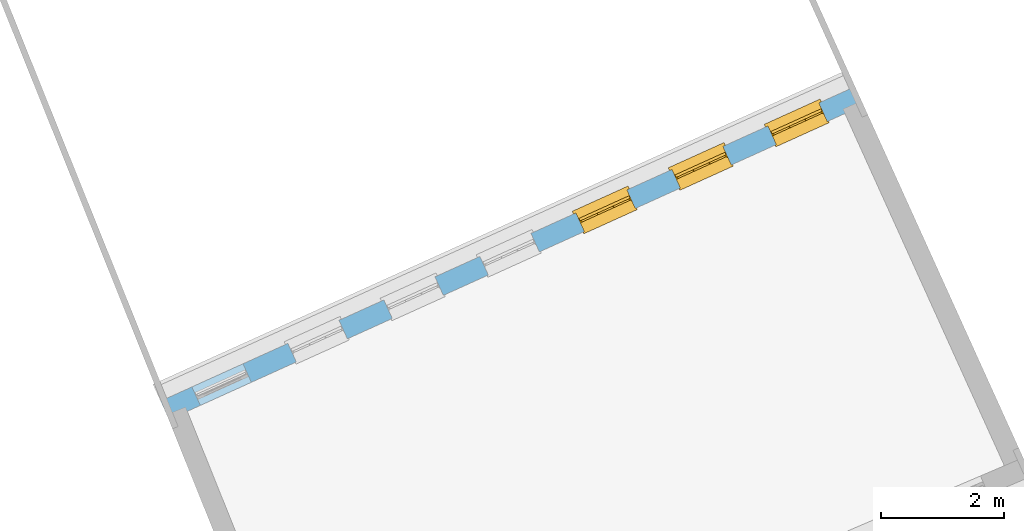
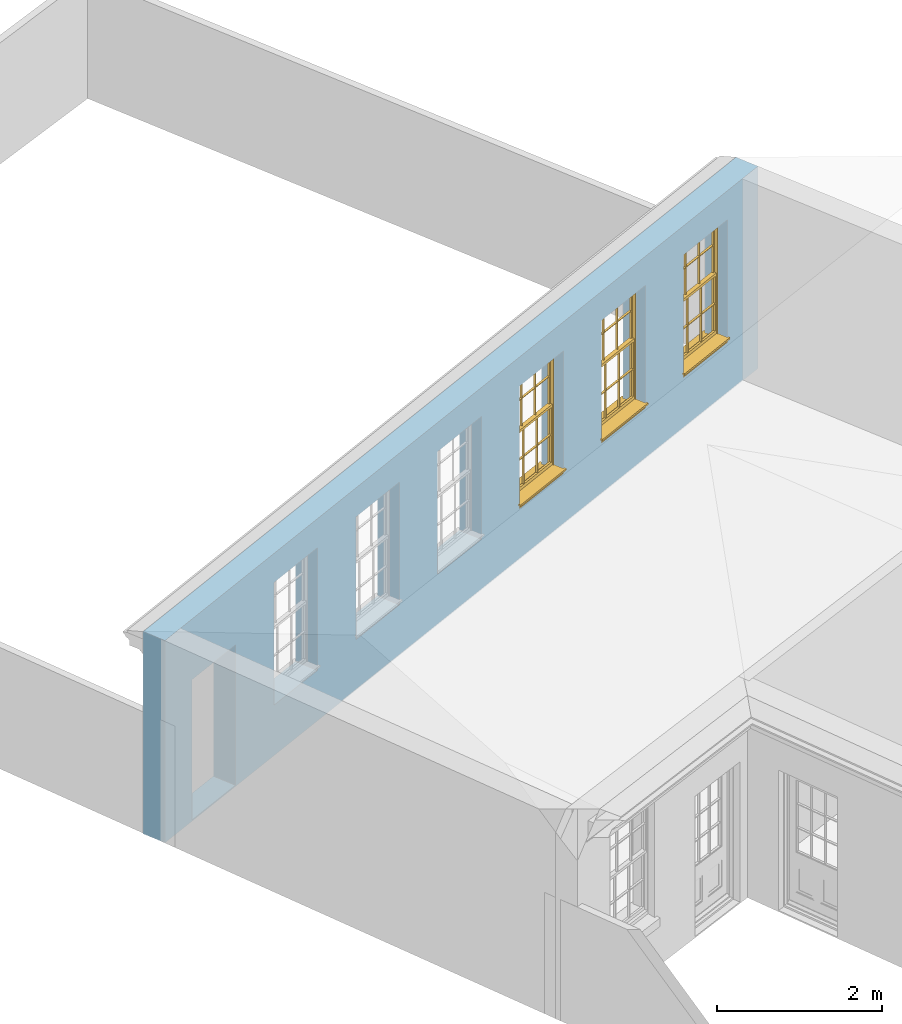
# One storey, part 15 of 19: 3 windows, 7 openings, plus 1 element that does not belong to this part.
"""IFC2X3 building model written with IfcOpenShell, lengths in metres."""

from ifc_helpers import new_model, si_unit, frame, origin, place, context, subcontext, project, spatial, polyline, outline, extrude, faceted_brep, material, layer, layer_set, layer_usage, element, fill, save


model = new_model("IFC2X3")

# Units and contexts
model_context = context("Model", 3, world=origin())
body_context = subcontext(model_context, "Body", "Model", "MODEL_VIEW")
ifc_project = project(units=[si_unit("PLANEANGLEUNIT", "RADIAN"), si_unit("MASSUNIT", "GRAM", prefix="KILO"), si_unit("FORCEUNIT", "NEWTON", prefix="KILO"), si_unit("LENGTHUNIT", "METRE")], contexts=[model_context])

# Site, building, storey
site_placement = place(None, origin())
site = spatial("IfcSite", under=ifc_project, at=site_placement, CompositionType="ELEMENT")
building_placement = place(None, origin())
building = spatial("IfcBuilding", under=site, at=building_placement, Name="Building plot-0", CompositionType="ELEMENT")
storey_placement = place(None, origin())
storey = spatial("IfcBuildingStorey", under=building, at=storey_placement, Name="Floor 0", CompositionType="ELEMENT", Elevation=0.0)

# Wall, openings, windows
ifc_material = material(Name="Masonry")
ifc_layer = layer(ifc_material, 0.33, ventilated=False)
ifc_layer_set = layer_set([ifc_layer], Name="My Wall")
ifc_layer_usage = layer_usage(ifc_layer_set, "AXIS2", "NEGATIVE", 0.08)
wall_placement = place(storey_placement, origin())
wall = element("IfcWallStandardCase", 1, at=wall_placement, inside=storey, material=ifc_layer_usage, Name="exterior", context=body_context, shape_type="SweptSolid", body=[
    extrude(outline(polyline([(21.5007118437475, 40.3889268355029), (21.3645733407012, 40.6895367288669), (10.0949852202286, 35.5858295970064), (10.2311237232749, 35.2852197036424), (21.5007118437475, 40.3889268355029)])), origin(), (0.0, 0.0, 1.0), 3.0),
])
opening_1_placement = place(storey_placement, frame((0.0, 0.0, 0.75)))
opening_1 = element("IfcOpeningElement", 2, at=opening_1_placement, cuts=wall, Name="Opening", ObjectType="Opening", context=body_context, shape_type="SweptSolid", body=[
    extrude(outline(polyline([(20.7788788084242, 40.4242907119302), (19.9499242539963, 40.048878476257), (20.0860627570426, 39.748268582893), (20.9150173114706, 40.1236808185662), (20.7788788084242, 40.4242907119302)])), origin(), (0.0, 0.0, 1.0), 1.82),
])
opening_2_placement = place(storey_placement, frame((0.0, 0.0, 0.75)))
opening_2 = element("IfcOpeningElement", 3, at=opening_2_placement, cuts=wall, Name="Opening", ObjectType="Opening", context=body_context, shape_type="SweptSolid", body=[
    extrude(outline(polyline([(19.2211729973563, 39.7188457415993), (18.3922184429283, 39.3434335059261), (18.5283569459746, 39.0428236125621), (19.3573115004026, 39.4182358482353), (19.2211729973563, 39.7188457415993)])), origin(), (0.0, 0.0, 1.0), 1.82),
])
opening_3_placement = place(storey_placement, frame((0.0, 0.0, 0.75)))
opening_3 = element("IfcOpeningElement", 4, at=opening_3_placement, cuts=wall, Name="Opening", ObjectType="Opening", context=body_context, shape_type="SweptSolid", body=[
    extrude(outline(polyline([(17.6634671862884, 39.0134007712684), (16.8345126318604, 38.6379885355952), (16.9706511349067, 38.3373786422312), (17.7996056893347, 38.7127908779044), (17.6634671862884, 39.0134007712684)])), origin(), (0.0, 0.0, 1.0), 1.82),
])
opening_4_placement = place(storey_placement, frame((0.0, 0.0, 0.75)))
element("IfcOpeningElement", 5, at=opening_4_placement, cuts=wall, Name="Opening", ObjectType="Opening", context=body_context, shape_type="SweptSolid", body=[
    extrude(outline(polyline([(16.1057613752204, 38.3079558009375), (15.2768068207924, 37.9325435652643), (15.4129453238388, 37.6319336719003), (16.2418998782667, 38.0073459075735), (16.1057613752204, 38.3079558009375)])), origin(), (0.0, 0.0, 1.0), 1.82),
])
opening_5_placement = place(storey_placement, frame((0.0, 0.0, 0.75)))
element("IfcOpeningElement", 6, at=opening_5_placement, cuts=wall, Name="Opening", ObjectType="Opening", context=body_context, shape_type="SweptSolid", body=[
    extrude(outline(polyline([(14.5480555641525, 37.6025108306066), (13.7191010097245, 37.2270985949334), (13.8552395127708, 36.9264887015694), (14.6841940671988, 37.3019009372426), (14.5480555641525, 37.6025108306066)])), origin(), (0.0, 0.0, 1.0), 1.82),
])
opening_6_placement = place(storey_placement, frame((0.0, 0.0, 0.75)))
element("IfcOpeningElement", 7, at=opening_6_placement, cuts=wall, Name="Opening", ObjectType="Opening", context=body_context, shape_type="SweptSolid", body=[
    extrude(outline(polyline([(12.9903497530845, 36.8970658602757), (12.1613951986565, 36.5216536246025), (12.2975337017029, 36.2210437312385), (13.1264882561308, 36.5964559669117), (12.9903497530845, 36.8970658602757)])), origin(), (0.0, 0.0, 1.0), 1.82),
])
opening_7_placement = place(storey_placement, frame((0.0, 0.0, 0.02)))
element("IfcOpeningElement", 8, at=opening_7_placement, cuts=wall, Name="Opening", ObjectType="Opening", context=body_context, shape_type="SweptSolid", body=[
    extrude(outline(polyline([(11.4326439420166, 36.1916208899448), (10.6036893875886, 35.8162086542716), (10.7398278906349, 35.5155987609077), (11.5687824450629, 35.8910109965808), (11.4326439420166, 36.1916208899448)])), origin(), (0.0, 0.0, 1.0), 2.08),
])
window_1_placement = place(storey_placement, frame((20.8820140380048, 40.1965559442302, 0.75), z_axis=(0.0, 0.0, 1.0), x_axis=(-0.82895455442797, -0.37541223567316, 0.0)))
window_1 = element("IfcWindow", 9, at=window_1_placement, inside=storey, Name="bedroom window", OverallHeight=1.82, OverallWidth=0.91, context=body_context, shape_type="Brep", held_by="IfcProductRepresentation", body=[
    faceted_brep([(0.033125, -0.105, 0.975209), (0.01, -0.105, 0.975209), (0.033125, -0.105, 1.376042), (0.876875, -0.105, 0.975209), (0.876875, -0.105, 1.376042), (0.9, -0.105, 0.975209), (0.876875, -0.105, 1.386042), (0.876875, -0.105, 1.786875), (0.9, -0.105, 1.81), (0.033125, -0.105, 1.786875), (0.033125, -0.105, 1.386042), (0.01, -0.105, 1.81), (0.876875, -0.135, 1.376042), (0.876875, -0.135, 0.975209), (0.9, -0.135, 0.937083), (0.033125, -0.135, 1.786875), (0.01, -0.135, 1.81), (0.033125, -0.135, 1.386042), (0.01, -0.135, 0.937083), (0.033125, -0.135, 0.975209), (0.033125, -0.135, 1.376042), (0.876875, -0.135, 1.786875), (0.876875, -0.135, 1.386042), (0.9, -0.135, 1.81), (0.033125, -0.105, 0.937083), (0.01, -0.105, 0.937083), (0.033125, -0.105, 0.53625), (0.876875, -0.105, 0.937083), (0.876875, -0.105, 0.53625), (0.9, -0.105, 0.937083), (0.876875, -0.105, 0.52625), (0.876875, -0.105, 0.125417), (0.9, -0.105, 0.077167), (0.033125, -0.105, 0.125417), (0.033125, -0.105, 0.52625), (0.01, -0.105, 0.077167), (-0.0425, -0.25, 0.01), (-0.0425, -0.3, 0.001667), (0.0, -0.25, 0.01), (0.9525, -0.25, 0.01), (0.91, -0.25, 0.01), (0.9525, -0.3, 0.001667), (-0.02, 0.08, 0.077167), (0.0, 0.08, 0.077167), (-0.02, 0.11, 0.077167), (0.0, -0.06, 0.077167), (0.01, -0.06, 0.077167), (0.91, -0.06, 0.077167), (0.91, 0.08, 0.077167), (0.9, -0.06, 0.077167), (0.93, 0.08, 0.077167), (0.93, 0.11, 0.077167), (0.01, -0.075, 0.975209), (0.9, -0.075, 0.975209), (0.876875, -0.075, 0.125417), (0.876875, -0.075, 0.52625), (0.9, -0.075, 0.077167), (0.876875, -0.075, 0.53625), (0.876875, -0.075, 0.937083), (0.033125, -0.075, 0.125417), (0.01, -0.075, 0.077167), (0.033125, -0.075, 0.52625), (0.033125, -0.075, 0.937083), (0.033125, -0.075, 0.53625), (-0.02, 0.08, 0.052167), (-0.02, 0.11, 0.052167), (0.93, 0.11, 0.052167), (0.93, 0.08, 0.052167), (0.91, 0.08, 0.052167), (0.0, 0.08, 0.052167), (0.91, -0.15, 0.026667), (0.0, -0.15, 0.026667), (-0.0425, -0.3, -0.123333), (0.9525, -0.3, -0.123333), (-0.0425, -0.25, -0.123333), (0.9525, -0.25, -0.123333), (0.01, -0.06, 1.81), (0.9, -0.06, 1.81), (0.0, -0.06, 1.82), (0.91, -0.06, 1.82), (0.01, -0.15, 0.077167), (0.9, -0.15, 0.077167), (0.592292, -0.105, 0.125417), (0.592292, -0.075, 0.125417), (0.317708, -0.075, 0.125417), (0.317708, -0.105, 0.125417), (0.592292, -0.105, 0.53625), (0.317708, -0.105, 0.53625), (0.317708, -0.105, 0.52625), (0.592292, -0.105, 0.52625), (0.592292, -0.075, 0.53625), (0.317708, -0.075, 0.53625), (0.592292, -0.135, 1.386042), (0.592292, -0.105, 1.386042), (0.317708, -0.105, 1.386042), (0.317708, -0.135, 1.386042), (0.317708, -0.135, 1.376042), (0.592292, -0.135, 1.376042), (0.317708, -0.105, 1.376042), (0.592292, -0.105, 1.376042), (0.602292, -0.135, 1.376042), (0.592292, -0.135, 0.975209), (0.602292, -0.135, 0.975209), (0.602292, -0.105, 0.975209), (0.592292, -0.105, 0.975209), (0.602292, -0.105, 1.376042), (0.602292, -0.075, 0.53625), (0.602292, -0.105, 0.53625), (0.317708, -0.075, 0.52625), (0.307708, -0.075, 0.125417), (0.307708, -0.075, 0.52625), (0.602292, -0.075, 0.52625), (0.602292, -0.075, 0.125417), (0.592292, -0.075, 0.52625), (0.307708, -0.075, 0.53625), (0.317708, -0.075, 0.937083), (0.307708, -0.075, 0.937083), (0.602292, -0.075, 0.937083), (0.592292, -0.075, 0.937083), (0.307708, -0.105, 0.52625), (0.307708, -0.105, 0.125417), (0.307708, -0.105, 0.53625), (0.307708, -0.105, 0.937083), (0.592292, -0.105, 0.937083), (0.317708, -0.105, 0.937083), (0.602292, -0.105, 0.937083), (0.602292, -0.105, 0.52625), (0.602292, -0.105, 0.125417), (0.307708, -0.135, 1.386042), (0.307708, -0.135, 1.376042), (0.307708, -0.135, 0.975209), (0.317708, -0.135, 0.975209), (0.317708, -0.135, 1.786875), (0.307708, -0.135, 1.786875), (0.602292, -0.135, 1.786875), (0.592292, -0.135, 1.786875), (0.602292, -0.135, 1.386042), (0.602292, -0.105, 1.386042), (0.307708, -0.105, 1.386042), (0.307708, -0.105, 1.786875), (0.317708, -0.105, 1.786875), (0.592292, -0.105, 1.786875), (0.602292, -0.105, 1.786875), (0.307708, -0.105, 1.376042), (0.317708, -0.105, 0.975209), (0.307708, -0.105, 0.975209), (0.91, -0.15, 1.82), (0.9, -0.15, 1.81), (0.01, -0.15, 1.81), (0.0, -0.15, 1.82), (0.91, -0.25, 0.0), (0.0, -0.25, 0.0), (0.91, 0.08, 0.0), (0.0, 0.08, 0.0)], [[[0, 1, 2]], [[3, 4, 5]], [[6, 7, 8]], [[9, 10, 11]], [[12, 13, 14]], [[15, 16, 17]], [[18, 19, 20]], [[21, 22, 23]], [[24, 25, 26]], [[27, 28, 29]], [[30, 31, 32]], [[33, 34, 35]], [[14, 27, 29]], [[25, 24, 18]], [[36, 37, 38]], [[39, 40, 41]], [[42, 43, 44]], [[45, 46, 43]], [[47, 48, 49]], [[50, 51, 48]], [[1, 0, 52]], [[5, 53, 3]], [[54, 55, 56]], [[57, 58, 53]], [[59, 60, 61]], [[62, 63, 52]], [[48, 43, 46, 49]], [[51, 44, 43, 48]], [[64, 42, 44, 65]], [[65, 44, 51, 66]], [[66, 51, 50, 67]], [[65, 66, 68, 69]], [[60, 56, 49, 46]], [[70, 71, 38, 40]], [[37, 41, 40, 38]], [[37, 72, 73, 41]], [[74, 75, 73, 72]], [[8, 11, 76, 77]], [[76, 78, 79, 77]], [[32, 35, 80, 81]], [[81, 80, 71, 70]], [[82, 83, 84, 85]], [[86, 87, 88, 89]], [[86, 90, 91, 87]], [[92, 93, 94, 95]], [[92, 95, 96, 97]], [[96, 98, 99, 97]], [[100, 97, 101, 102]], [[103, 104, 99, 105]], [[97, 99, 104, 101]], [[102, 103, 105, 100]], [[28, 57, 106, 107]], [[108, 84, 109, 110]], [[111, 112, 83, 113]], [[114, 110, 61, 63]], [[90, 113, 108, 91]], [[115, 91, 114, 116]], [[117, 106, 90, 118]], [[111, 106, 57, 55]], [[119, 110, 109, 120]], [[34, 61, 110, 119]], [[89, 113, 83, 82]], [[88, 108, 113, 89]], [[85, 84, 108, 88]], [[121, 114, 63, 26]], [[122, 116, 114, 121]], [[123, 118, 90, 86]], [[87, 91, 115, 124]], [[107, 106, 117, 125]], [[126, 111, 55, 30]], [[127, 112, 111, 126]], [[126, 30, 28, 107]], [[88, 119, 120, 85]], [[126, 89, 82, 127]], [[125, 123, 86, 107]], [[121, 26, 34, 119]], [[124, 122, 121, 87]], [[128, 17, 20, 129]], [[96, 129, 130, 131]], [[132, 133, 128, 95]], [[134, 135, 92, 136]], [[100, 12, 22, 136]], [[137, 6, 4, 105]], [[94, 138, 139, 140]], [[137, 93, 141, 142]], [[99, 98, 94, 93]], [[143, 2, 10, 138]], [[144, 145, 143, 98]], [[129, 143, 145, 130]], [[20, 2, 143, 129]], [[131, 144, 98, 96]], [[128, 138, 10, 17]], [[133, 139, 138, 128]], [[135, 141, 93, 92]], [[95, 94, 140, 132]], [[22, 6, 137, 136]], [[136, 137, 142, 134]], [[100, 105, 4, 12]], [[107, 86, 89, 126]], [[106, 111, 113, 90]], [[91, 108, 110, 114]], [[87, 121, 119, 88]], [[97, 100, 136, 92]], [[129, 96, 95, 128]], [[98, 143, 138, 94]], [[105, 99, 93, 137]], [[131, 101, 104, 144]], [[124, 115, 118, 123]], [[132, 140, 141, 135]], [[120, 109, 59, 33]], [[15, 9, 139, 133]], [[134, 142, 7, 21]], [[31, 54, 112, 127]], [[36, 74, 72, 37]], [[39, 41, 73, 75]], [[18, 14, 101, 131]], [[23, 16, 132, 135]], [[83, 56, 60, 84]], [[52, 53, 118, 115]], [[53, 52, 144, 104]], [[11, 8, 141, 140]], [[14, 18, 124, 123]], [[2, 1, 11, 10]], [[8, 5, 4, 6]], [[57, 53, 56, 55]], [[60, 52, 63, 61]], [[26, 25, 35, 34]], [[32, 29, 28, 30]], [[14, 23, 22, 12]], [[18, 20, 17, 16]], [[19, 0, 2, 20]], [[17, 10, 9, 15]], [[12, 4, 3, 13]], [[21, 7, 6, 22]], [[27, 58, 57, 28]], [[30, 55, 54, 31]], [[33, 59, 61, 34]], [[26, 63, 62, 24]], [[5, 8, 77, 53]], [[76, 11, 1, 52]], [[46, 45, 78, 76]], [[49, 77, 79, 47]], [[70, 146, 147, 81]], [[71, 80, 148, 149]], [[19, 130, 145, 0]], [[102, 13, 3, 103]], [[116, 122, 24, 62]], [[29, 32, 81, 14]], [[80, 35, 25, 18]], [[60, 46, 76, 52]], [[77, 49, 56, 53]], [[23, 14, 81, 147]], [[16, 148, 80, 18]], [[35, 85, 120]], [[120, 33, 35]], [[127, 82, 32]], [[32, 31, 127]], [[32, 82, 85, 35]], [[102, 101, 14]], [[14, 13, 102]], [[18, 131, 130]], [[130, 19, 18]], [[134, 21, 23]], [[23, 135, 134]], [[16, 15, 133]], [[133, 132, 16]], [[11, 140, 139]], [[139, 9, 11]], [[142, 141, 8]], [[8, 7, 142]], [[23, 147, 148, 16]], [[146, 149, 148, 147]], [[52, 115, 116]], [[116, 62, 52]], [[118, 53, 117]], [[58, 117, 53]], [[27, 125, 117, 58]], [[56, 83, 112]], [[112, 54, 56]], [[109, 84, 60]], [[60, 59, 109]], [[125, 27, 14]], [[14, 123, 125]], [[122, 124, 18]], [[18, 24, 122]], [[145, 144, 52]], [[52, 0, 145]], [[103, 3, 53]], [[53, 104, 103]], [[79, 78, 149, 146]], [[78, 45, 71, 149]], [[146, 70, 47, 79]], [[150, 75, 74, 151]], [[68, 66, 67]], [[48, 68, 67, 50]], [[69, 64, 65]], [[42, 64, 69, 43]], [[69, 68, 152, 153]], [[70, 68, 48, 47]], [[150, 152, 68, 70]], [[43, 69, 71, 45]], [[69, 153, 151, 71]], [[152, 150, 151, 153]], [[38, 151, 74, 36]], [[71, 151, 38]], [[39, 75, 150, 40]], [[40, 150, 70]]]),
])
fill(opening_1, window_1)
window_2_placement = place(storey_placement, frame((19.3243082269368, 39.4911109738993, 0.75), z_axis=(0.0, 0.0, 1.0), x_axis=(-0.828954554427973, -0.375412235673167, 0.0)))
window_2 = element("IfcWindow", 10, at=window_2_placement, inside=storey, Name="bedroom window", OverallHeight=1.82, OverallWidth=0.91, context=body_context, shape_type="Brep", held_by="IfcProductRepresentation", body=[
    faceted_brep([(0.033125, -0.105, 0.975209), (0.01, -0.105, 0.975209), (0.033125, -0.105, 1.376042), (0.876875, -0.105, 0.975209), (0.876875, -0.105, 1.376042), (0.9, -0.105, 0.975209), (0.876875, -0.105, 1.386042), (0.876875, -0.105, 1.786875), (0.9, -0.105, 1.81), (0.033125, -0.105, 1.786875), (0.033125, -0.105, 1.386042), (0.01, -0.105, 1.81), (0.876875, -0.135, 1.376042), (0.876875, -0.135, 0.975209), (0.9, -0.135, 0.937083), (0.033125, -0.135, 1.786875), (0.01, -0.135, 1.81), (0.033125, -0.135, 1.386042), (0.01, -0.135, 0.937083), (0.033125, -0.135, 0.975209), (0.033125, -0.135, 1.376042), (0.876875, -0.135, 1.786875), (0.876875, -0.135, 1.386042), (0.9, -0.135, 1.81), (0.033125, -0.105, 0.937083), (0.01, -0.105, 0.937083), (0.033125, -0.105, 0.53625), (0.876875, -0.105, 0.937083), (0.876875, -0.105, 0.53625), (0.9, -0.105, 0.937083), (0.876875, -0.105, 0.52625), (0.876875, -0.105, 0.125417), (0.9, -0.105, 0.077167), (0.033125, -0.105, 0.125417), (0.033125, -0.105, 0.52625), (0.01, -0.105, 0.077167), (-0.0425, -0.25, 0.01), (-0.0425, -0.3, 0.001667), (0.0, -0.25, 0.01), (0.9525, -0.25, 0.01), (0.91, -0.25, 0.01), (0.9525, -0.3, 0.001667), (-0.02, 0.08, 0.077167), (0.0, 0.08, 0.077167), (-0.02, 0.11, 0.077167), (0.0, -0.06, 0.077167), (0.01, -0.06, 0.077167), (0.91, -0.06, 0.077167), (0.91, 0.08, 0.077167), (0.9, -0.06, 0.077167), (0.93, 0.08, 0.077167), (0.93, 0.11, 0.077167), (0.01, -0.075, 0.975209), (0.9, -0.075, 0.975209), (0.876875, -0.075, 0.125417), (0.876875, -0.075, 0.52625), (0.9, -0.075, 0.077167), (0.876875, -0.075, 0.53625), (0.876875, -0.075, 0.937083), (0.033125, -0.075, 0.125417), (0.01, -0.075, 0.077167), (0.033125, -0.075, 0.52625), (0.033125, -0.075, 0.937083), (0.033125, -0.075, 0.53625), (-0.02, 0.08, 0.052167), (-0.02, 0.11, 0.052167), (0.93, 0.11, 0.052167), (0.93, 0.08, 0.052167), (0.91, 0.08, 0.052167), (0.0, 0.08, 0.052167), (0.91, -0.15, 0.026667), (0.0, -0.15, 0.026667), (-0.0425, -0.3, -0.123333), (0.9525, -0.3, -0.123333), (-0.0425, -0.25, -0.123333), (0.9525, -0.25, -0.123333), (0.01, -0.06, 1.81), (0.9, -0.06, 1.81), (0.0, -0.06, 1.82), (0.91, -0.06, 1.82), (0.01, -0.15, 0.077167), (0.9, -0.15, 0.077167), (0.592292, -0.105, 0.125417), (0.592292, -0.075, 0.125417), (0.317708, -0.075, 0.125417), (0.317708, -0.105, 0.125417), (0.592292, -0.105, 0.53625), (0.317708, -0.105, 0.53625), (0.317708, -0.105, 0.52625), (0.592292, -0.105, 0.52625), (0.592292, -0.075, 0.53625), (0.317708, -0.075, 0.53625), (0.592292, -0.135, 1.386042), (0.592292, -0.105, 1.386042), (0.317708, -0.105, 1.386042), (0.317708, -0.135, 1.386042), (0.317708, -0.135, 1.376042), (0.592292, -0.135, 1.376042), (0.317708, -0.105, 1.376042), (0.592292, -0.105, 1.376042), (0.602292, -0.135, 1.376042), (0.592292, -0.135, 0.975209), (0.602292, -0.135, 0.975209), (0.602292, -0.105, 0.975209), (0.592292, -0.105, 0.975209), (0.602292, -0.105, 1.376042), (0.602292, -0.075, 0.53625), (0.602292, -0.105, 0.53625), (0.317708, -0.075, 0.52625), (0.307708, -0.075, 0.125417), (0.307708, -0.075, 0.52625), (0.602292, -0.075, 0.52625), (0.602292, -0.075, 0.125417), (0.592292, -0.075, 0.52625), (0.307708, -0.075, 0.53625), (0.317708, -0.075, 0.937083), (0.307708, -0.075, 0.937083), (0.602292, -0.075, 0.937083), (0.592292, -0.075, 0.937083), (0.307708, -0.105, 0.52625), (0.307708, -0.105, 0.125417), (0.307708, -0.105, 0.53625), (0.307708, -0.105, 0.937083), (0.592292, -0.105, 0.937083), (0.317708, -0.105, 0.937083), (0.602292, -0.105, 0.937083), (0.602292, -0.105, 0.52625), (0.602292, -0.105, 0.125417), (0.307708, -0.135, 1.386042), (0.307708, -0.135, 1.376042), (0.307708, -0.135, 0.975209), (0.317708, -0.135, 0.975209), (0.317708, -0.135, 1.786875), (0.307708, -0.135, 1.786875), (0.602292, -0.135, 1.786875), (0.592292, -0.135, 1.786875), (0.602292, -0.135, 1.386042), (0.602292, -0.105, 1.386042), (0.307708, -0.105, 1.386042), (0.307708, -0.105, 1.786875), (0.317708, -0.105, 1.786875), (0.592292, -0.105, 1.786875), (0.602292, -0.105, 1.786875), (0.307708, -0.105, 1.376042), (0.317708, -0.105, 0.975209), (0.307708, -0.105, 0.975209), (0.91, -0.15, 1.82), (0.9, -0.15, 1.81), (0.01, -0.15, 1.81), (0.0, -0.15, 1.82), (0.91, -0.25, 0.0), (0.0, -0.25, 0.0), (0.91, 0.08, 0.0), (0.0, 0.08, 0.0)], [[[0, 1, 2]], [[3, 4, 5]], [[6, 7, 8]], [[9, 10, 11]], [[12, 13, 14]], [[15, 16, 17]], [[18, 19, 20]], [[21, 22, 23]], [[24, 25, 26]], [[27, 28, 29]], [[30, 31, 32]], [[33, 34, 35]], [[14, 27, 29]], [[25, 24, 18]], [[36, 37, 38]], [[39, 40, 41]], [[42, 43, 44]], [[45, 46, 43]], [[47, 48, 49]], [[50, 51, 48]], [[1, 0, 52]], [[5, 53, 3]], [[54, 55, 56]], [[57, 58, 53]], [[59, 60, 61]], [[62, 63, 52]], [[48, 43, 46, 49]], [[51, 44, 43, 48]], [[64, 42, 44, 65]], [[65, 44, 51, 66]], [[66, 51, 50, 67]], [[65, 66, 68, 69]], [[60, 56, 49, 46]], [[70, 71, 38, 40]], [[37, 41, 40, 38]], [[37, 72, 73, 41]], [[74, 75, 73, 72]], [[8, 11, 76, 77]], [[76, 78, 79, 77]], [[32, 35, 80, 81]], [[81, 80, 71, 70]], [[82, 83, 84, 85]], [[86, 87, 88, 89]], [[86, 90, 91, 87]], [[92, 93, 94, 95]], [[92, 95, 96, 97]], [[96, 98, 99, 97]], [[100, 97, 101, 102]], [[103, 104, 99, 105]], [[97, 99, 104, 101]], [[102, 103, 105, 100]], [[28, 57, 106, 107]], [[108, 84, 109, 110]], [[111, 112, 83, 113]], [[114, 110, 61, 63]], [[90, 113, 108, 91]], [[115, 91, 114, 116]], [[117, 106, 90, 118]], [[111, 106, 57, 55]], [[119, 110, 109, 120]], [[34, 61, 110, 119]], [[89, 113, 83, 82]], [[88, 108, 113, 89]], [[85, 84, 108, 88]], [[121, 114, 63, 26]], [[122, 116, 114, 121]], [[123, 118, 90, 86]], [[87, 91, 115, 124]], [[107, 106, 117, 125]], [[126, 111, 55, 30]], [[127, 112, 111, 126]], [[126, 30, 28, 107]], [[88, 119, 120, 85]], [[126, 89, 82, 127]], [[125, 123, 86, 107]], [[121, 26, 34, 119]], [[124, 122, 121, 87]], [[128, 17, 20, 129]], [[96, 129, 130, 131]], [[132, 133, 128, 95]], [[134, 135, 92, 136]], [[100, 12, 22, 136]], [[137, 6, 4, 105]], [[94, 138, 139, 140]], [[137, 93, 141, 142]], [[99, 98, 94, 93]], [[143, 2, 10, 138]], [[144, 145, 143, 98]], [[129, 143, 145, 130]], [[20, 2, 143, 129]], [[131, 144, 98, 96]], [[128, 138, 10, 17]], [[133, 139, 138, 128]], [[135, 141, 93, 92]], [[95, 94, 140, 132]], [[22, 6, 137, 136]], [[136, 137, 142, 134]], [[100, 105, 4, 12]], [[107, 86, 89, 126]], [[106, 111, 113, 90]], [[91, 108, 110, 114]], [[87, 121, 119, 88]], [[97, 100, 136, 92]], [[129, 96, 95, 128]], [[98, 143, 138, 94]], [[105, 99, 93, 137]], [[131, 101, 104, 144]], [[124, 115, 118, 123]], [[132, 140, 141, 135]], [[120, 109, 59, 33]], [[15, 9, 139, 133]], [[134, 142, 7, 21]], [[31, 54, 112, 127]], [[36, 74, 72, 37]], [[39, 41, 73, 75]], [[18, 14, 101, 131]], [[23, 16, 132, 135]], [[83, 56, 60, 84]], [[52, 53, 118, 115]], [[53, 52, 144, 104]], [[11, 8, 141, 140]], [[14, 18, 124, 123]], [[2, 1, 11, 10]], [[8, 5, 4, 6]], [[57, 53, 56, 55]], [[60, 52, 63, 61]], [[26, 25, 35, 34]], [[32, 29, 28, 30]], [[14, 23, 22, 12]], [[18, 20, 17, 16]], [[19, 0, 2, 20]], [[17, 10, 9, 15]], [[12, 4, 3, 13]], [[21, 7, 6, 22]], [[27, 58, 57, 28]], [[30, 55, 54, 31]], [[33, 59, 61, 34]], [[26, 63, 62, 24]], [[5, 8, 77, 53]], [[76, 11, 1, 52]], [[46, 45, 78, 76]], [[49, 77, 79, 47]], [[70, 146, 147, 81]], [[71, 80, 148, 149]], [[19, 130, 145, 0]], [[102, 13, 3, 103]], [[116, 122, 24, 62]], [[29, 32, 81, 14]], [[80, 35, 25, 18]], [[60, 46, 76, 52]], [[77, 49, 56, 53]], [[23, 14, 81, 147]], [[16, 148, 80, 18]], [[35, 85, 120]], [[120, 33, 35]], [[127, 82, 32]], [[32, 31, 127]], [[32, 82, 85, 35]], [[102, 101, 14]], [[14, 13, 102]], [[18, 131, 130]], [[130, 19, 18]], [[134, 21, 23]], [[23, 135, 134]], [[16, 15, 133]], [[133, 132, 16]], [[11, 140, 139]], [[139, 9, 11]], [[142, 141, 8]], [[8, 7, 142]], [[23, 147, 148, 16]], [[146, 149, 148, 147]], [[52, 115, 116]], [[116, 62, 52]], [[118, 53, 117]], [[58, 117, 53]], [[27, 125, 117, 58]], [[56, 83, 112]], [[112, 54, 56]], [[109, 84, 60]], [[60, 59, 109]], [[125, 27, 14]], [[14, 123, 125]], [[122, 124, 18]], [[18, 24, 122]], [[145, 144, 52]], [[52, 0, 145]], [[103, 3, 53]], [[53, 104, 103]], [[79, 78, 149, 146]], [[78, 45, 71, 149]], [[146, 70, 47, 79]], [[150, 75, 74, 151]], [[68, 66, 67]], [[48, 68, 67, 50]], [[69, 64, 65]], [[42, 64, 69, 43]], [[69, 68, 152, 153]], [[70, 68, 48, 47]], [[150, 152, 68, 70]], [[43, 69, 71, 45]], [[69, 153, 151, 71]], [[152, 150, 151, 153]], [[38, 151, 74, 36]], [[71, 151, 38]], [[39, 75, 150, 40]], [[40, 150, 70]]]),
])
fill(opening_2, window_2)
window_3_placement = place(storey_placement, frame((17.7666024158689, 38.7856660035684, 0.75), z_axis=(0.0, 0.0, 1.0), x_axis=(-0.828954554427973, -0.375412235673167, 0.0)))
window_3 = element("IfcWindow", 11, at=window_3_placement, inside=storey, Name="bedroom window", OverallHeight=1.82, OverallWidth=0.91, context=body_context, shape_type="Brep", held_by="IfcProductRepresentation", body=[
    faceted_brep([(0.033125, -0.105, 0.975209), (0.01, -0.105, 0.975209), (0.033125, -0.105, 1.376042), (0.876875, -0.105, 0.975209), (0.876875, -0.105, 1.376042), (0.9, -0.105, 0.975209), (0.876875, -0.105, 1.386042), (0.876875, -0.105, 1.786875), (0.9, -0.105, 1.81), (0.033125, -0.105, 1.786875), (0.033125, -0.105, 1.386042), (0.01, -0.105, 1.81), (0.876875, -0.135, 1.376042), (0.876875, -0.135, 0.975209), (0.9, -0.135, 0.937083), (0.033125, -0.135, 1.786875), (0.01, -0.135, 1.81), (0.033125, -0.135, 1.386042), (0.01, -0.135, 0.937083), (0.033125, -0.135, 0.975209), (0.033125, -0.135, 1.376042), (0.876875, -0.135, 1.786875), (0.876875, -0.135, 1.386042), (0.9, -0.135, 1.81), (0.033125, -0.105, 0.937083), (0.01, -0.105, 0.937083), (0.033125, -0.105, 0.53625), (0.876875, -0.105, 0.937083), (0.876875, -0.105, 0.53625), (0.9, -0.105, 0.937083), (0.876875, -0.105, 0.52625), (0.876875, -0.105, 0.125417), (0.9, -0.105, 0.077167), (0.033125, -0.105, 0.125417), (0.033125, -0.105, 0.52625), (0.01, -0.105, 0.077167), (-0.0425, -0.25, 0.01), (-0.0425, -0.3, 0.001667), (0.0, -0.25, 0.01), (0.9525, -0.25, 0.01), (0.91, -0.25, 0.01), (0.9525, -0.3, 0.001667), (-0.02, 0.08, 0.077167), (0.0, 0.08, 0.077167), (-0.02, 0.11, 0.077167), (0.0, -0.06, 0.077167), (0.01, -0.06, 0.077167), (0.91, -0.06, 0.077167), (0.91, 0.08, 0.077167), (0.9, -0.06, 0.077167), (0.93, 0.08, 0.077167), (0.93, 0.11, 0.077167), (0.01, -0.075, 0.975209), (0.9, -0.075, 0.975209), (0.876875, -0.075, 0.125417), (0.876875, -0.075, 0.52625), (0.9, -0.075, 0.077167), (0.876875, -0.075, 0.53625), (0.876875, -0.075, 0.937083), (0.033125, -0.075, 0.125417), (0.01, -0.075, 0.077167), (0.033125, -0.075, 0.52625), (0.033125, -0.075, 0.937083), (0.033125, -0.075, 0.53625), (-0.02, 0.08, 0.052167), (-0.02, 0.11, 0.052167), (0.93, 0.11, 0.052167), (0.93, 0.08, 0.052167), (0.91, 0.08, 0.052167), (0.0, 0.08, 0.052167), (0.91, -0.15, 0.026667), (0.0, -0.15, 0.026667), (-0.0425, -0.3, -0.123333), (0.9525, -0.3, -0.123333), (-0.0425, -0.25, -0.123333), (0.9525, -0.25, -0.123333), (0.01, -0.06, 1.81), (0.9, -0.06, 1.81), (0.0, -0.06, 1.82), (0.91, -0.06, 1.82), (0.01, -0.15, 0.077167), (0.9, -0.15, 0.077167), (0.592292, -0.105, 0.125417), (0.592292, -0.075, 0.125417), (0.317708, -0.075, 0.125417), (0.317708, -0.105, 0.125417), (0.592292, -0.105, 0.53625), (0.317708, -0.105, 0.53625), (0.317708, -0.105, 0.52625), (0.592292, -0.105, 0.52625), (0.592292, -0.075, 0.53625), (0.317708, -0.075, 0.53625), (0.592292, -0.135, 1.386042), (0.592292, -0.105, 1.386042), (0.317708, -0.105, 1.386042), (0.317708, -0.135, 1.386042), (0.317708, -0.135, 1.376042), (0.592292, -0.135, 1.376042), (0.317708, -0.105, 1.376042), (0.592292, -0.105, 1.376042), (0.602292, -0.135, 1.376042), (0.592292, -0.135, 0.975209), (0.602292, -0.135, 0.975209), (0.602292, -0.105, 0.975209), (0.592292, -0.105, 0.975209), (0.602292, -0.105, 1.376042), (0.602292, -0.075, 0.53625), (0.602292, -0.105, 0.53625), (0.317708, -0.075, 0.52625), (0.307708, -0.075, 0.125417), (0.307708, -0.075, 0.52625), (0.602292, -0.075, 0.52625), (0.602292, -0.075, 0.125417), (0.592292, -0.075, 0.52625), (0.307708, -0.075, 0.53625), (0.317708, -0.075, 0.937083), (0.307708, -0.075, 0.937083), (0.602292, -0.075, 0.937083), (0.592292, -0.075, 0.937083), (0.307708, -0.105, 0.52625), (0.307708, -0.105, 0.125417), (0.307708, -0.105, 0.53625), (0.307708, -0.105, 0.937083), (0.592292, -0.105, 0.937083), (0.317708, -0.105, 0.937083), (0.602292, -0.105, 0.937083), (0.602292, -0.105, 0.52625), (0.602292, -0.105, 0.125417), (0.307708, -0.135, 1.386042), (0.307708, -0.135, 1.376042), (0.307708, -0.135, 0.975209), (0.317708, -0.135, 0.975209), (0.317708, -0.135, 1.786875), (0.307708, -0.135, 1.786875), (0.602292, -0.135, 1.786875), (0.592292, -0.135, 1.786875), (0.602292, -0.135, 1.386042), (0.602292, -0.105, 1.386042), (0.307708, -0.105, 1.386042), (0.307708, -0.105, 1.786875), (0.317708, -0.105, 1.786875), (0.592292, -0.105, 1.786875), (0.602292, -0.105, 1.786875), (0.307708, -0.105, 1.376042), (0.317708, -0.105, 0.975209), (0.307708, -0.105, 0.975209), (0.91, -0.15, 1.82), (0.9, -0.15, 1.81), (0.01, -0.15, 1.81), (0.0, -0.15, 1.82), (0.91, -0.25, 0.0), (0.0, -0.25, 0.0), (0.91, 0.08, 0.0), (0.0, 0.08, 0.0)], [[[0, 1, 2]], [[3, 4, 5]], [[6, 7, 8]], [[9, 10, 11]], [[12, 13, 14]], [[15, 16, 17]], [[18, 19, 20]], [[21, 22, 23]], [[24, 25, 26]], [[27, 28, 29]], [[30, 31, 32]], [[33, 34, 35]], [[14, 27, 29]], [[25, 24, 18]], [[36, 37, 38]], [[39, 40, 41]], [[42, 43, 44]], [[45, 46, 43]], [[47, 48, 49]], [[50, 51, 48]], [[1, 0, 52]], [[5, 53, 3]], [[54, 55, 56]], [[57, 58, 53]], [[59, 60, 61]], [[62, 63, 52]], [[48, 43, 46, 49]], [[51, 44, 43, 48]], [[64, 42, 44, 65]], [[65, 44, 51, 66]], [[66, 51, 50, 67]], [[65, 66, 68, 69]], [[60, 56, 49, 46]], [[70, 71, 38, 40]], [[37, 41, 40, 38]], [[37, 72, 73, 41]], [[74, 75, 73, 72]], [[8, 11, 76, 77]], [[76, 78, 79, 77]], [[32, 35, 80, 81]], [[81, 80, 71, 70]], [[82, 83, 84, 85]], [[86, 87, 88, 89]], [[86, 90, 91, 87]], [[92, 93, 94, 95]], [[92, 95, 96, 97]], [[96, 98, 99, 97]], [[100, 97, 101, 102]], [[103, 104, 99, 105]], [[97, 99, 104, 101]], [[102, 103, 105, 100]], [[28, 57, 106, 107]], [[108, 84, 109, 110]], [[111, 112, 83, 113]], [[114, 110, 61, 63]], [[90, 113, 108, 91]], [[115, 91, 114, 116]], [[117, 106, 90, 118]], [[111, 106, 57, 55]], [[119, 110, 109, 120]], [[34, 61, 110, 119]], [[89, 113, 83, 82]], [[88, 108, 113, 89]], [[85, 84, 108, 88]], [[121, 114, 63, 26]], [[122, 116, 114, 121]], [[123, 118, 90, 86]], [[87, 91, 115, 124]], [[107, 106, 117, 125]], [[126, 111, 55, 30]], [[127, 112, 111, 126]], [[126, 30, 28, 107]], [[88, 119, 120, 85]], [[126, 89, 82, 127]], [[125, 123, 86, 107]], [[121, 26, 34, 119]], [[124, 122, 121, 87]], [[128, 17, 20, 129]], [[96, 129, 130, 131]], [[132, 133, 128, 95]], [[134, 135, 92, 136]], [[100, 12, 22, 136]], [[137, 6, 4, 105]], [[94, 138, 139, 140]], [[137, 93, 141, 142]], [[99, 98, 94, 93]], [[143, 2, 10, 138]], [[144, 145, 143, 98]], [[129, 143, 145, 130]], [[20, 2, 143, 129]], [[131, 144, 98, 96]], [[128, 138, 10, 17]], [[133, 139, 138, 128]], [[135, 141, 93, 92]], [[95, 94, 140, 132]], [[22, 6, 137, 136]], [[136, 137, 142, 134]], [[100, 105, 4, 12]], [[107, 86, 89, 126]], [[106, 111, 113, 90]], [[91, 108, 110, 114]], [[87, 121, 119, 88]], [[97, 100, 136, 92]], [[129, 96, 95, 128]], [[98, 143, 138, 94]], [[105, 99, 93, 137]], [[131, 101, 104, 144]], [[124, 115, 118, 123]], [[132, 140, 141, 135]], [[120, 109, 59, 33]], [[15, 9, 139, 133]], [[134, 142, 7, 21]], [[31, 54, 112, 127]], [[36, 74, 72, 37]], [[39, 41, 73, 75]], [[18, 14, 101, 131]], [[23, 16, 132, 135]], [[83, 56, 60, 84]], [[52, 53, 118, 115]], [[53, 52, 144, 104]], [[11, 8, 141, 140]], [[14, 18, 124, 123]], [[2, 1, 11, 10]], [[8, 5, 4, 6]], [[57, 53, 56, 55]], [[60, 52, 63, 61]], [[26, 25, 35, 34]], [[32, 29, 28, 30]], [[14, 23, 22, 12]], [[18, 20, 17, 16]], [[19, 0, 2, 20]], [[17, 10, 9, 15]], [[12, 4, 3, 13]], [[21, 7, 6, 22]], [[27, 58, 57, 28]], [[30, 55, 54, 31]], [[33, 59, 61, 34]], [[26, 63, 62, 24]], [[5, 8, 77, 53]], [[76, 11, 1, 52]], [[46, 45, 78, 76]], [[49, 77, 79, 47]], [[70, 146, 147, 81]], [[71, 80, 148, 149]], [[19, 130, 145, 0]], [[102, 13, 3, 103]], [[116, 122, 24, 62]], [[29, 32, 81, 14]], [[80, 35, 25, 18]], [[60, 46, 76, 52]], [[77, 49, 56, 53]], [[23, 14, 81, 147]], [[16, 148, 80, 18]], [[35, 85, 120]], [[120, 33, 35]], [[127, 82, 32]], [[32, 31, 127]], [[32, 82, 85, 35]], [[102, 101, 14]], [[14, 13, 102]], [[18, 131, 130]], [[130, 19, 18]], [[134, 21, 23]], [[23, 135, 134]], [[16, 15, 133]], [[133, 132, 16]], [[11, 140, 139]], [[139, 9, 11]], [[142, 141, 8]], [[8, 7, 142]], [[23, 147, 148, 16]], [[146, 149, 148, 147]], [[52, 115, 116]], [[116, 62, 52]], [[118, 53, 117]], [[58, 117, 53]], [[27, 125, 117, 58]], [[56, 83, 112]], [[112, 54, 56]], [[109, 84, 60]], [[60, 59, 109]], [[125, 27, 14]], [[14, 123, 125]], [[122, 124, 18]], [[18, 24, 122]], [[145, 144, 52]], [[52, 0, 145]], [[103, 3, 53]], [[53, 104, 103]], [[79, 78, 149, 146]], [[78, 45, 71, 149]], [[146, 70, 47, 79]], [[150, 75, 74, 151]], [[68, 66, 67]], [[48, 68, 67, 50]], [[69, 64, 65]], [[42, 64, 69, 43]], [[69, 68, 152, 153]], [[70, 68, 48, 47]], [[150, 152, 68, 70]], [[43, 69, 71, 45]], [[69, 153, 151, 71]], [[152, 150, 151, 153]], [[38, 151, 74, 36]], [[71, 151, 38]], [[39, 75, 150, 40]], [[40, 150, 70]]]),
])
fill(opening_3, window_3)

save(model, "model.ifc")
